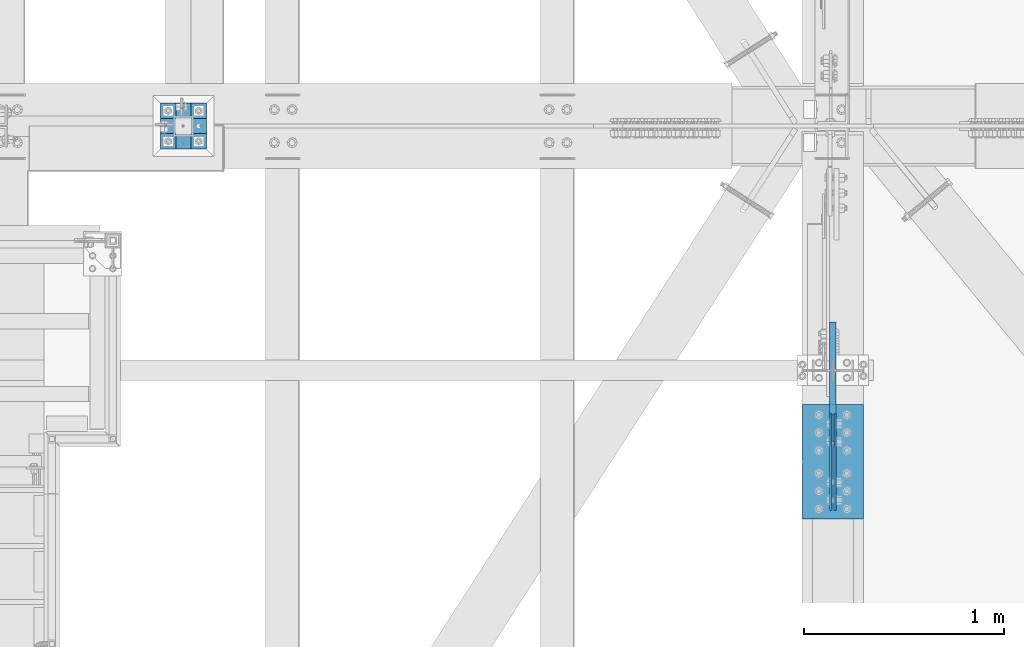
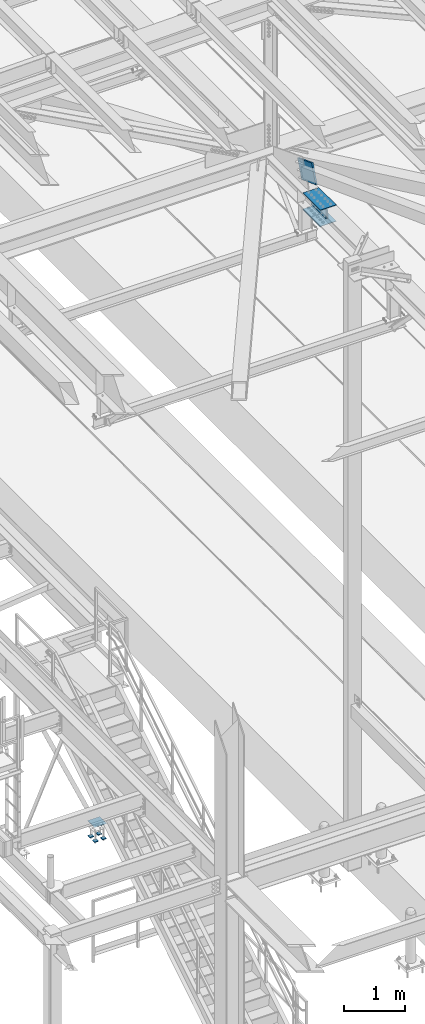
# One storey, part 2176 of 3843: 9 beams, 1 member, 3 elements without a shape of their own.
"""IFC2X3 building model written with IfcOpenShell, lengths in millimetres."""

from ifc_helpers import new_model, si_unit, frame, origin_with_axes, place, context, subcontext, project, spatial, faceted_brep, material, type_object, element, aggregate, save


model = new_model("IFC2X3")

# Units and contexts
model_context = context("Model", 3, precision=1e-05, world=origin_with_axes())
body_context = subcontext(model_context, "Body", "Model", "MODEL_VIEW")
ifc_project = project(units=[si_unit("LENGTHUNIT", "METRE", prefix="MILLI"), si_unit("AREAUNIT", "SQUARE_METRE"), si_unit("VOLUMEUNIT", "CUBIC_METRE"), si_unit("MASSUNIT", "GRAM", prefix="KILO"), si_unit("TIMEUNIT", "SECOND"), si_unit("PLANEANGLEUNIT", "RADIAN"), si_unit("SOLIDANGLEUNIT", "STERADIAN"), si_unit("THERMODYNAMICTEMPERATUREUNIT", "DEGREE_CELSIUS"), si_unit("LUMINOUSINTENSITYUNIT", "LUMEN")], contexts=[model_context])

# Site, building, storey
site_placement = place(None, origin_with_axes())
site = spatial("IfcSite", under=ifc_project, at=site_placement, CompositionType="ELEMENT")
building_placement = place(site_placement, origin_with_axes())
building = spatial("IfcBuilding", under=site, at=building_placement, Name="Undefined", CompositionType="ELEMENT")
storey_placement = place(building_placement, origin_with_axes())
storey = spatial("IfcBuildingStorey", under=building, at=storey_placement, Name="Undefined", CompositionType="ELEMENT", Elevation=0.0)

# Assembly, beams
assembly_1_placement = place(storey_placement, origin_with_axes())
assembly_1 = element("IfcElementAssembly", 1, at=assembly_1_placement, inside=storey, Name="BEAM", AssemblyPlace="NOTDEFINED", PredefinedType="RIGID_FRAME")
ifc_material = material(Name="STEEL/A572-50")
beam_type_1 = type_object("IfcBeamType", PredefinedType="NOTDEFINED")
beam_1_placement = place(assembly_1_placement, frame((42051.2875, 32410.3999874739, 42248.7369908151), z_axis=(0.0, -0.000321877000067616, 0.999999948197597), x_axis=(0.0, -0.999999948197597, -0.000321877000061539)))
beam_1 = element("IfcBeam", 2, at=beam_1_placement, type_object=beam_type_1, material=ifc_material, Name="PLATE", context=body_context, shape_type="Brep", body=[
    faceted_brep([(-4.65661287307739e-10, 4.76249999999709, -88.9000000002779), (0.0, 4.76249999999709, 88.9000015258789), (482.600000007384, 4.76249999999709, 88.9000000010856), (482.60000000638, 4.76249999999709, -88.8999999994776), (0.0, -4.76249999999709, 88.9000015258789), (482.600000007384, -4.76249999999709, 88.9000000010856), (-4.65661287307739e-10, -4.76249999999709, -88.9000000002779), (482.60000000638, -4.76249999999709, -88.8999999994776)], [[[0, 1, 2, 3]], [[1, 4, 5, 2]], [[4, 6, 7, 5]], [[6, 0, 3, 7]], [[5, 7, 3, 2]], [[6, 4, 1, 0]]]),
])
beam_2_placement = place(assembly_1_placement, frame((42073.5125, 32410.3999874739, 42248.7369908151), z_axis=(0.0, -0.000321877000067616, 0.999999948197597), x_axis=(0.0, -0.999999948197597, -0.000321877000061539)))
beam_2 = element("IfcBeam", 3, at=beam_2_placement, type_object=beam_type_1, material=ifc_material, Name="PLATE", context=body_context, shape_type="Brep", body=[
    faceted_brep([(-4.65661287307739e-10, 4.76249999999709, -88.9000000002779), (0.0, 4.76249999999709, 88.9000015258789), (482.600000007384, 4.76249999999709, 88.9000000010856), (482.60000000638, 4.76249999999709, -88.8999999994776), (0.0, -4.76249999999709, 88.9000015258789), (482.600000007384, -4.76249999999709, 88.9000000010856), (-4.65661287307739e-10, -4.76249999999709, -88.9000000002779), (482.60000000638, -4.76249999999709, -88.8999999994776)], [[[0, 1, 2, 3]], [[1, 4, 5, 2]], [[4, 6, 7, 5]], [[6, 0, 3, 7]], [[5, 7, 3, 2]], [[6, 4, 1, 0]]]),
])
beam_type_2 = type_object("IfcBeamType", PredefinedType="NOTDEFINED")
beam_3_placement = place(assembly_1_placement, frame((42062.4, 32454.9021051049, 42086.8263066376), z_axis=(-1.0, 0.0, 0.0), x_axis=(0.0, -0.999999948197597, -0.000321877000061539)))
beam_3 = element("IfcBeam", 4, at=beam_3_placement, type_object=beam_type_2, material=ifc_material, Name="PLATE", context=body_context, shape_type="Brep", body=[
    faceted_brep([(2.91038304567337e-11, 4.76250000001892, -152.400000000001), (2.91038304567337e-11, 4.76250000001892, 152.400000000001), (571.500000008222, 4.76250000096479, 152.400000000001), (571.500000008222, 4.76250000096479, -152.400000000001), (-2.91038304567337e-11, -4.76250000001164, 152.400000000001), (571.500000008164, -4.76249999906577, 152.400000000001), (-2.91038304567337e-11, -4.76250000001164, -152.400000000001), (571.500000008164, -4.76249999906577, -152.400000000001)], [[[0, 1, 2, 3]], [[1, 4, 5, 2]], [[4, 6, 7, 5]], [[6, 0, 3, 7]], [[5, 7, 3, 2]], [[6, 4, 1, 0]]]),
])
beam_4_placement = place(assembly_1_placement, frame((42062.4, 32454.7978652385, 42410.6762898562), z_axis=(-1.0, 0.0, 0.0), x_axis=(0.0, -0.999999948197597, -0.000321877000061539)))
beam_4 = element("IfcBeam", 5, at=beam_4_placement, type_object=beam_type_2, material=ifc_material, Name="PLATE", context=body_context, shape_type="Brep", body=[
    faceted_brep([(2.91038304567337e-11, 4.76250000001892, -152.400000000001), (2.91038304567337e-11, 4.76250000001892, 152.400000000001), (571.500000008222, 4.76250000096479, 152.400000000001), (571.500000008222, 4.76250000096479, -152.400000000001), (-2.91038304567337e-11, -4.76250000001164, 152.400000000001), (571.500000008164, -4.76249999906577, 152.400000000001), (-2.91038304567337e-11, -4.76250000001164, -152.400000000001), (571.500000008164, -4.76249999906577, -152.400000000001)], [[[0, 1, 2, 3]], [[1, 4, 5, 2]], [[4, 6, 7, 5]], [[6, 0, 3, 7]], [[5, 7, 3, 2]], [[6, 4, 1, 0]]]),
])
aggregate(assembly_1, [beam_1, beam_2, beam_3, beam_4])

# Assembly, member
assembly_2_placement = place(storey_placement, origin_with_axes())
assembly_2 = element("IfcElementAssembly", 6, at=assembly_2_placement, inside=storey, AssemblyPlace="NOTDEFINED", PredefinedType="RIGID_FRAME")
member_type = type_object("IfcMemberType", PredefinedType="NOTDEFINED")
member_placement = place(assembly_2_placement, frame((42062.4000000002, 32800.4665661507, 42641.708919321), z_axis=(0.0, 0.351612260031988, 0.936145725085148), x_axis=(0.0, -0.936145725085148, 0.351612260031987)))
member = element("IfcMember", 7, at=member_placement, type_object=member_type, material=ifc_material, Name="PLATE", context=body_context, shape_type="Brep", body=[
    faceted_brep([(3.56521923094988e-10, 15.875, -190.500000000146), (-3.61978891305625e-10, 15.875, 190.500000000153), (495.299999995012, 15.875, 190.500000001084), (495.299999995726, 15.875, -190.499999999221), (-3.61978891305625e-10, -15.875, 190.500000000153), (495.299999995012, -15.875, 190.500000001084), (3.56521923094988e-10, -15.875, -190.500000000146), (495.299999995726, -15.875, -190.499999999221)], [[[0, 1, 2, 3]], [[1, 4, 5, 2]], [[4, 6, 7, 5]], [[6, 0, 3, 7]], [[5, 7, 3, 2]], [[6, 4, 1, 0]]]),
])
aggregate(assembly_2, [member])

# Assembly, beams
assembly_3_placement = place(storey_placement, origin_with_axes())
assembly_3 = element("IfcElementAssembly", 8, at=assembly_3_placement, inside=storey, Name="TEMPLATE", AssemblyPlace="NOTDEFINED", PredefinedType="RIGID_FRAME")
beam_type_3 = type_object("IfcBeamType", PredefinedType="NOTDEFINED")
beam_5_placement = place(assembly_3_placement, frame((38935.025, 33769.3, 29762.45), z_axis=(0.0, 1.0, 0.0), x_axis=(-1.0, 0.0, 0.0)))
beam_5 = element("IfcBeam", 9, at=beam_5_placement, type_object=beam_type_3, material=ifc_material, context=body_context, shape_type="Brep", body=[
    faceted_brep([(0.0, 6.34999999999854, -38.1000000000058), (0.0, 6.34999999999854, 38.0999984741211), (76.1999999999971, 6.34999999999854, 38.1000000000058), (76.1999999999971, 6.34999999999854, -38.1000000000058), (0.0, -6.34999999999854, 38.0999984741211), (76.1999999999971, -6.34999999999854, 38.1000000000058), (0.0, -6.34999999999854, -38.1000000000058), (76.1999999999971, -6.34999999999854, -38.1000000000058)], [[[0, 1, 2, 3]], [[1, 4, 5, 2]], [[4, 6, 7, 5]], [[6, 0, 3, 7]], [[5, 7, 3, 2]], [[6, 4, 1, 0]]]),
])
beam_6_placement = place(assembly_3_placement, frame((38935.025, 33921.7, 29762.45), z_axis=(0.0, 1.0, 0.0), x_axis=(-1.0, 0.0, 0.0)))
beam_6 = element("IfcBeam", 10, at=beam_6_placement, type_object=beam_type_3, material=ifc_material, context=body_context, shape_type="Brep", body=[
    faceted_brep([(0.0, 6.34999999999854, -38.1000000000058), (0.0, 6.34999999999854, 38.0999984741211), (76.1999999999971, 6.34999999999854, 38.1000000000058), (76.1999999999971, 6.34999999999854, -38.1000000000058), (0.0, -6.34999999999854, 38.0999984741211), (76.1999999999971, -6.34999999999854, 38.1000000000058), (0.0, -6.34999999999854, -38.1000000000058), (76.1999999999971, -6.34999999999854, -38.1000000000058)], [[[0, 1, 2, 3]], [[1, 4, 5, 2]], [[4, 6, 7, 5]], [[6, 0, 3, 7]], [[5, 7, 3, 2]], [[6, 4, 1, 0]]]),
])
beam_7_placement = place(assembly_3_placement, frame((38782.625, 33769.3, 29762.45), z_axis=(0.0, 1.0, 0.0), x_axis=(-1.0, 0.0, 0.0)))
beam_7 = element("IfcBeam", 11, at=beam_7_placement, type_object=beam_type_3, material=ifc_material, context=body_context, shape_type="Brep", body=[
    faceted_brep([(0.0, 6.34999999999854, -38.1000000000058), (0.0, 6.34999999999854, 38.0999984741211), (76.1999999999971, 6.34999999999854, 38.1000000000058), (76.1999999999971, 6.34999999999854, -38.1000000000058), (0.0, -6.34999999999854, 38.0999984741211), (76.1999999999971, -6.34999999999854, 38.1000000000058), (0.0, -6.34999999999854, -38.1000000000058), (76.1999999999971, -6.34999999999854, -38.1000000000058)], [[[0, 1, 2, 3]], [[1, 4, 5, 2]], [[4, 6, 7, 5]], [[6, 0, 3, 7]], [[5, 7, 3, 2]], [[6, 4, 1, 0]]]),
])
beam_8_placement = place(assembly_3_placement, frame((38782.625, 33921.7, 29762.45), z_axis=(0.0, 1.0, 0.0), x_axis=(-1.0, 0.0, 0.0)))
beam_8 = element("IfcBeam", 12, at=beam_8_placement, type_object=beam_type_3, material=ifc_material, context=body_context, shape_type="Brep", body=[
    faceted_brep([(0.0, 6.34999999999854, -38.1000000000058), (0.0, 6.34999999999854, 38.0999984741211), (76.1999999999971, 6.34999999999854, 38.1000000000058), (76.1999999999971, 6.34999999999854, -38.1000000000058), (0.0, -6.34999999999854, 38.0999984741211), (76.1999999999971, -6.34999999999854, 38.1000000000058), (0.0, -6.34999999999854, -38.1000000000058), (76.1999999999971, -6.34999999999854, -38.1000000000058)], [[[0, 1, 2, 3]], [[1, 4, 5, 2]], [[4, 6, 7, 5]], [[6, 0, 3, 7]], [[5, 7, 3, 2]], [[6, 4, 1, 0]]]),
])
beam_type_4 = type_object("IfcBeamType", PredefinedType="NOTDEFINED")
beam_9_placement = place(assembly_3_placement, frame((38935.025, 33845.5, 30062.4875), z_axis=(0.0, -1.0, 0.0), x_axis=(-1.0, 0.0, 0.0)))
beam_9 = element("IfcBeam", 13, at=beam_9_placement, type_object=beam_type_4, material=ifc_material, Name="TEMPLATE", context=body_context, shape_type="Brep", body=[
    faceted_brep([(0.0, 1.58750000000146, -114.300000000003), (0.0, 1.58750000000146, 114.300000000003), (228.600000000006, 1.58750000000146, 114.300000000003), (228.600000000006, 1.58750000000146, -114.300000000003), (0.0, -1.58750000000146, 114.300000000003), (228.600000000006, -1.58750000000146, 114.300000000003), (0.0, -1.58750000000146, -114.300000000003), (228.600000000006, -1.58750000000146, -114.300000000003)], [[[0, 1, 2, 3]], [[1, 4, 5, 2]], [[4, 6, 7, 5]], [[6, 0, 3, 7]], [[5, 7, 3, 2]], [[6, 4, 1, 0]]]),
])
aggregate(assembly_3, [beam_5, beam_6, beam_7, beam_8, beam_9])

save(model, "model.ifc")
